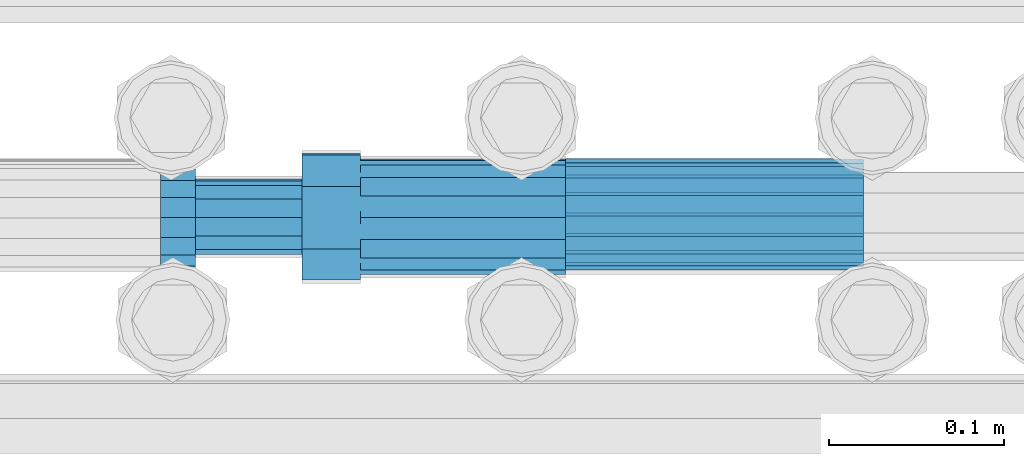
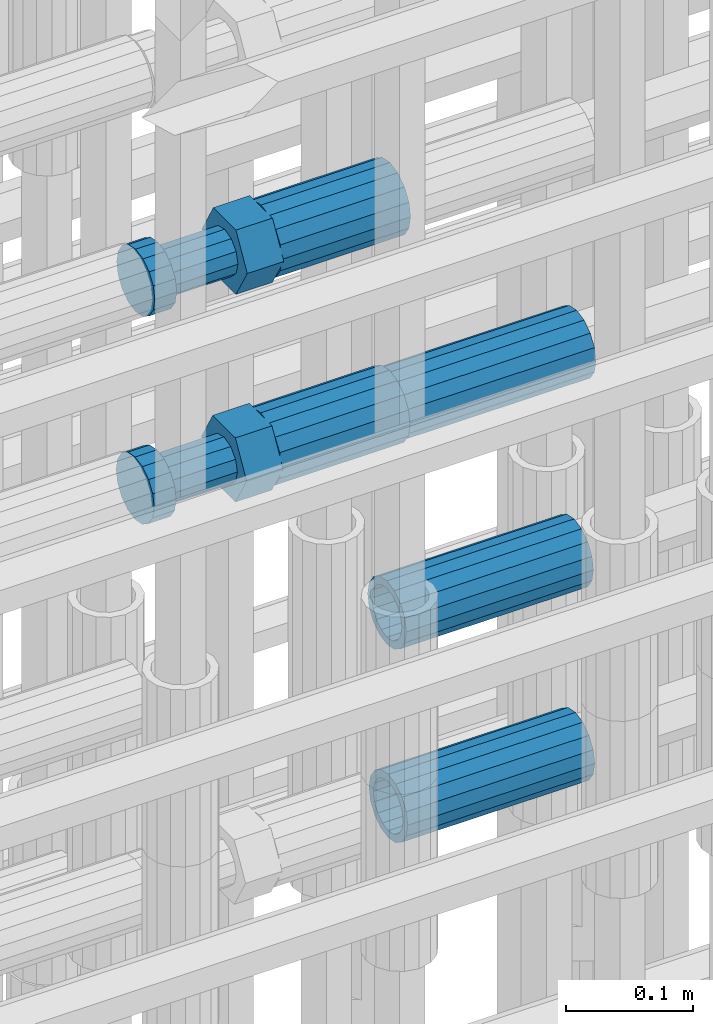
# One storey, part 27 of 119: 5 beams.
"""IFC2X3 building model written with IfcOpenShell, lengths in millimetres."""

from ifc_helpers import new_model, si_unit, frame, origin_with_axes, place, context, subcontext, project, spatial, faceted_brep, material, type_object, element, save


model = new_model("IFC2X3")

# Units and contexts
model_context = context("Model", 3, precision=1e-05, world=origin_with_axes())
body_context = subcontext(model_context, "Body", "Model", "MODEL_VIEW")
ifc_project = project(units=[si_unit("LENGTHUNIT", "METRE", prefix="MILLI"), si_unit("AREAUNIT", "SQUARE_METRE"), si_unit("VOLUMEUNIT", "CUBIC_METRE"), si_unit("MASSUNIT", "GRAM", prefix="KILO"), si_unit("TIMEUNIT", "SECOND"), si_unit("PLANEANGLEUNIT", "RADIAN"), si_unit("SOLIDANGLEUNIT", "STERADIAN"), si_unit("THERMODYNAMICTEMPERATUREUNIT", "DEGREE_CELSIUS"), si_unit("LUMINOUSINTENSITYUNIT", "LUMEN")], contexts=[model_context])

# Site, building, storey
site_placement = place(None, origin_with_axes())
site = spatial("IfcSite", under=ifc_project, at=site_placement, CompositionType="ELEMENT")
building_placement = place(site_placement, origin_with_axes())
building = spatial("IfcBuilding", under=site, at=building_placement, Name="Undefined", CompositionType="ELEMENT")
storey_placement = place(building_placement, origin_with_axes())
storey = spatial("IfcBuildingStorey", under=building, at=storey_placement, Name="Undefined", CompositionType="ELEMENT", Elevation=0.0)

# Beams
ifc_material = material(Name="STEEL/S275")
beam_type_1 = type_object("IfcBeamType", PredefinedType="NOTDEFINED")
beam_1_placement = place(storey_placement, frame((2035520.01345925, 6205213.05560864, 20146.6568409387), z_axis=(0.0, 0.0, 1.0), x_axis=(-0.999999999998145, -1.92600247614167e-06, 0.0)))
element("IfcBeam", 1, at=beam_1_placement, inside=storey, type_object=beam_type_1, material=ifc_material, Name="AG40N", context=body_context, shape_type="Brep", body=[
    faceted_brep([(1.62981450557709e-09, -23.4999999990687, 0.0), (7.45058059692383e-09, -21.7111690142192, 8.99306066057534), (170.000002125278, -21.711168999318, 8.99306066022245), (170.000002127141, -23.4999999844003, -3.66071617463604e-10), (4.65661287307739e-09, -16.6170093587134, 16.6170093578889), (170.000002122484, -16.6170093440451, 16.6170093575288), (1.86264514923096e-09, -8.99306066217832, 21.7111690140277), (170.000002118759, -8.99306064750999, 21.7111690136603), (2.3283064365387e-10, 9.31322574615479e-10, 23.5), (170.000002114102, 1.28056854009628e-08, 23.4999999996485), (-6.51925802230835e-09, 8.99306065868586, 21.7111690140241), (170.00000211224, 8.99306067335419, 21.7111690136639), (-7.45058059692383e-09, 16.6170093561523, 16.6170093578853), (170.000002109446, 16.6170093708206, 16.6170093575324), (-9.31322574615479e-09, 21.711169013055, 8.99306066057534), (170.000002108514, 21.7111690277234, 8.99306066022245), (-1.16415321826935e-09, 23.5000000009313, 0.0), (170.000002108514, 23.5000000144355, -3.66071617463604e-10), (-8.38190317153931e-09, 21.7111690151505, -8.99306066059444), (170.000002110377, 21.7111690300517, -8.9930606609546), (-5.58793544769287e-09, 16.6170093598776, -16.6170093579008), (170.000002113171, 16.6170093745459, -16.6170093582609), (-9.31322574615479e-10, 8.99306066334248, -21.7111690140396), (170.000002115965, 8.99306067801081, -21.7111690143961), (2.3283064365387e-10, 9.31322574615479e-10, -23.5), (170.00000211969, 1.7927959561348e-08, -23.5000000003843), (5.58793544769287e-09, -8.99306065752171, -21.7111690140396), (170.000002123415, -8.99306064285338, -21.7111690143961), (8.38190317153931e-09, -16.6170093549881, -16.6170093579008), (170.000002125278, -16.6170093403198, -16.6170093582646), (9.31322574615479e-09, -21.7111690121237, -8.99306066059444), (170.000002127141, -21.7111689972226, -8.9930606609546), (1.11758708953857e-08, -30.4999999990687, -9.54969436861575e-12), (1.30385160446167e-08, -28.1783257392235, -11.6718446871514), (170.000002129003, -28.1783257243223, -11.6718446875116), (170.000002129935, -30.4999999841675, -3.66071617463604e-10), (1.02445483207703e-08, -21.5667568228673, -21.5667568262129), (170.000002128072, -21.566756808199, -21.5667568265694), (7.45058059692383e-09, -11.6718446831219, -28.1783257416196), (170.000002125278, -11.6718446684536, -28.1783257419834), (3.72529029846191e-09, 3.95812094211578e-09, -30.5000000000277), (170.00000211969, 1.83936208486557e-08, -30.5000000003879), (-9.31322574615479e-10, 11.6718446905725, -28.1783257416232), (170.000002115965, 11.6718447052408, -28.1783257419797), (-6.51925802230835e-09, 21.5667568286881, -21.5667568262093), (170.000002110377, 21.5667568433564, -21.5667568265694), (-9.31322574615479e-09, 28.178325742716, -11.6718446871478), (170.000002108514, 28.1783257573843, -11.6718446875079), (-1.21071934700012e-08, 30.5, -5.91171556152403e-12), (170.000002106652, 30.5000000144355, -3.62433638656512e-10), (-1.21071934700012e-08, 28.1783257401548, 11.6718446871359), (170.00000210572, 28.1783257548232, 11.6718446867794), (-1.02445483207703e-08, 21.5667568240315, 21.5667568261974), (170.000002107583, 21.566756838467, 21.5667568258409), (-7.45058059692383e-09, 11.671844684286, 28.1783257416041), (170.000002110377, 11.6718446989544, 28.178325741244), (-2.79396772384644e-09, -2.56113708019257e-09, 30.5000000000159), (170.000002114102, 1.18743628263474e-08, 30.4999999996558), (1.86264514923096e-09, -11.6718446896411, 28.1783257416114), (170.000002118759, -11.67184467474, 28.178325741244), (7.45058059692383e-09, -21.5667568275239, 21.5667568261974), (170.000002123415, -21.5667568126228, 21.5667568258373), (1.02445483207703e-08, -28.1783257415518, 11.6718446871359), (170.000002127141, -28.1783257271163, 11.6718446867794)], [[[0, 1, 2, 3]], [[1, 4, 5, 2]], [[4, 6, 7, 5]], [[6, 8, 9, 7]], [[8, 10, 11, 9]], [[10, 12, 13, 11]], [[12, 14, 15, 13]], [[14, 16, 17, 15]], [[16, 18, 19, 17]], [[18, 20, 21, 19]], [[20, 22, 23, 21]], [[22, 24, 25, 23]], [[24, 26, 27, 25]], [[26, 28, 29, 27]], [[28, 30, 31, 29]], [[30, 0, 3, 31]], [[32, 33, 34, 35]], [[33, 36, 37, 34]], [[36, 38, 39, 37]], [[38, 40, 41, 39]], [[40, 42, 43, 41]], [[42, 44, 45, 43]], [[44, 46, 47, 45]], [[46, 48, 49, 47]], [[48, 50, 51, 49]], [[50, 52, 53, 51]], [[52, 54, 55, 53]], [[54, 56, 57, 55]], [[56, 58, 59, 57]], [[58, 60, 61, 59]], [[60, 62, 63, 61]], [[62, 32, 35, 63]], [[37, 39, 41, 43, 45, 47, 49, 51, 53, 55, 57, 59, 61, 63, 35, 34], [5, 7, 9, 11, 13, 15, 17, 19, 21, 23, 25, 27, 29, 31, 3, 2]], [[62, 60, 58, 56, 54, 52, 50, 48, 46, 44, 42, 40, 38, 36, 33, 32], [30, 28, 26, 24, 22, 20, 18, 16, 14, 12, 10, 8, 6, 4, 1, 0]]]),
])
beam_2_placement = place(storey_placement, frame((2035519.01345925, 6205215.21560864, 19945.3068409387), z_axis=(0.0, 0.0, 1.0), x_axis=(-0.999999999998145, -1.92600247614167e-06, 0.0)))
element("IfcBeam", 2, at=beam_2_placement, inside=storey, type_object=beam_type_1, material=ifc_material, Name="AG40N", context=body_context, shape_type="Brep", body=[
    faceted_brep([(1.62981450557709e-09, -23.4999999990687, 0.0), (7.45058059692383e-09, -21.7111690142192, 8.99306066057534), (170.000002125278, -21.711168999318, 8.99306066022245), (170.000002127141, -23.4999999844003, -3.66071617463604e-10), (4.65661287307739e-09, -16.6170093587134, 16.6170093578889), (170.000002122484, -16.6170093440451, 16.6170093575288), (1.86264514923096e-09, -8.99306066217832, 21.7111690140277), (170.000002118759, -8.99306064750999, 21.7111690136603), (2.3283064365387e-10, 9.31322574615479e-10, 23.5), (170.000002114102, 1.28056854009628e-08, 23.4999999996485), (-6.51925802230835e-09, 8.99306065868586, 21.7111690140241), (170.00000211224, 8.99306067335419, 21.7111690136639), (-7.45058059692383e-09, 16.6170093561523, 16.6170093578853), (170.000002109446, 16.6170093708206, 16.6170093575324), (-9.31322574615479e-09, 21.711169013055, 8.99306066057534), (170.000002108514, 21.7111690277234, 8.99306066022245), (-1.16415321826935e-09, 23.5000000009313, 0.0), (170.000002108514, 23.5000000144355, -3.66071617463604e-10), (-8.38190317153931e-09, 21.7111690151505, -8.99306066059444), (170.000002110377, 21.7111690300517, -8.9930606609546), (-5.58793544769287e-09, 16.6170093598776, -16.6170093579008), (170.000002113171, 16.6170093745459, -16.6170093582609), (-9.31322574615479e-10, 8.99306066334248, -21.7111690140396), (170.000002115965, 8.99306067801081, -21.7111690143961), (2.3283064365387e-10, 9.31322574615479e-10, -23.5), (170.00000211969, 1.7927959561348e-08, -23.5000000003843), (5.58793544769287e-09, -8.99306065752171, -21.7111690140396), (170.000002123415, -8.99306064285338, -21.7111690143961), (8.38190317153931e-09, -16.6170093549881, -16.6170093579008), (170.000002125278, -16.6170093403198, -16.6170093582646), (9.31322574615479e-09, -21.7111690121237, -8.99306066059444), (170.000002127141, -21.7111689972226, -8.9930606609546), (1.11758708953857e-08, -30.4999999990687, -9.54969436861575e-12), (1.30385160446167e-08, -28.1783257392235, -11.6718446871514), (170.000002129003, -28.1783257243223, -11.6718446875116), (170.000002129935, -30.4999999841675, -3.66071617463604e-10), (1.02445483207703e-08, -21.5667568228673, -21.5667568262129), (170.000002128072, -21.566756808199, -21.5667568265694), (7.45058059692383e-09, -11.6718446831219, -28.1783257416196), (170.000002125278, -11.6718446684536, -28.1783257419834), (3.72529029846191e-09, 3.95812094211578e-09, -30.5000000000277), (170.00000211969, 1.83936208486557e-08, -30.5000000003879), (-9.31322574615479e-10, 11.6718446905725, -28.1783257416232), (170.000002115965, 11.6718447052408, -28.1783257419797), (-6.51925802230835e-09, 21.5667568286881, -21.5667568262093), (170.000002110377, 21.5667568433564, -21.5667568265694), (-9.31322574615479e-09, 28.178325742716, -11.6718446871478), (170.000002108514, 28.1783257573843, -11.6718446875079), (-1.21071934700012e-08, 30.5, -5.91171556152403e-12), (170.000002106652, 30.5000000144355, -3.62433638656512e-10), (-1.21071934700012e-08, 28.1783257401548, 11.6718446871359), (170.00000210572, 28.1783257548232, 11.6718446867794), (-1.02445483207703e-08, 21.5667568240315, 21.5667568261974), (170.000002107583, 21.566756838467, 21.5667568258409), (-7.45058059692383e-09, 11.671844684286, 28.1783257416041), (170.000002110377, 11.6718446989544, 28.178325741244), (-2.79396772384644e-09, -2.56113708019257e-09, 30.5000000000159), (170.000002114102, 1.18743628263474e-08, 30.4999999996558), (1.86264514923096e-09, -11.6718446896411, 28.1783257416114), (170.000002118759, -11.67184467474, 28.178325741244), (7.45058059692383e-09, -21.5667568275239, 21.5667568261974), (170.000002123415, -21.5667568126228, 21.5667568258373), (1.02445483207703e-08, -28.1783257415518, 11.6718446871359), (170.000002127141, -28.1783257271163, 11.6718446867794)], [[[0, 1, 2, 3]], [[1, 4, 5, 2]], [[4, 6, 7, 5]], [[6, 8, 9, 7]], [[8, 10, 11, 9]], [[10, 12, 13, 11]], [[12, 14, 15, 13]], [[14, 16, 17, 15]], [[16, 18, 19, 17]], [[18, 20, 21, 19]], [[20, 22, 23, 21]], [[22, 24, 25, 23]], [[24, 26, 27, 25]], [[26, 28, 29, 27]], [[28, 30, 31, 29]], [[30, 0, 3, 31]], [[32, 33, 34, 35]], [[33, 36, 37, 34]], [[36, 38, 39, 37]], [[38, 40, 41, 39]], [[40, 42, 43, 41]], [[42, 44, 45, 43]], [[44, 46, 47, 45]], [[46, 48, 49, 47]], [[48, 50, 51, 49]], [[50, 52, 53, 51]], [[52, 54, 55, 53]], [[54, 56, 57, 55]], [[56, 58, 59, 57]], [[58, 60, 61, 59]], [[60, 62, 63, 61]], [[62, 32, 35, 63]], [[37, 39, 41, 43, 45, 47, 49, 51, 53, 55, 57, 59, 61, 63, 35, 34], [5, 7, 9, 11, 13, 15, 17, 19, 21, 23, 25, 27, 29, 31, 3, 2]], [[62, 60, 58, 56, 54, 52, 50, 48, 46, 44, 42, 40, 38, 36, 33, 32], [30, 28, 26, 24, 22, 20, 18, 16, 14, 12, 10, 8, 6, 4, 1, 0]]]),
])
beam_3_placement = place(storey_placement, frame((2035519.99345925, 6205214.81562195, 19759.4968409387), z_axis=(0.0, 0.0, 1.0), x_axis=(-0.999999999998145, -1.92600247614167e-06, 0.0)))
element("IfcBeam", 3, at=beam_3_placement, inside=storey, type_object=beam_type_1, material=ifc_material, Name="AG40N", context=body_context, shape_type="Brep", body=[
    faceted_brep([(1.62981450557709e-09, -23.4999999990687, 0.0), (7.45058059692383e-09, -21.7111690142192, 8.99306066057534), (170.000002125278, -21.711168999318, 8.99306066022245), (170.000002127141, -23.4999999844003, -3.66071617463604e-10), (4.65661287307739e-09, -16.6170093587134, 16.6170093578889), (170.000002122484, -16.6170093440451, 16.6170093575288), (1.86264514923096e-09, -8.99306066217832, 21.7111690140277), (170.000002118759, -8.99306064750999, 21.7111690136603), (2.3283064365387e-10, 9.31322574615479e-10, 23.5), (170.000002114102, 1.28056854009628e-08, 23.4999999996485), (-6.51925802230835e-09, 8.99306065868586, 21.7111690140241), (170.00000211224, 8.99306067335419, 21.7111690136639), (-7.45058059692383e-09, 16.6170093561523, 16.6170093578853), (170.000002109446, 16.6170093708206, 16.6170093575324), (-9.31322574615479e-09, 21.711169013055, 8.99306066057534), (170.000002108514, 21.7111690277234, 8.99306066022245), (-1.16415321826935e-09, 23.5000000009313, 0.0), (170.000002108514, 23.5000000144355, -3.66071617463604e-10), (-8.38190317153931e-09, 21.7111690151505, -8.99306066059444), (170.000002110377, 21.7111690300517, -8.9930606609546), (-5.58793544769287e-09, 16.6170093598776, -16.6170093579008), (170.000002113171, 16.6170093745459, -16.6170093582609), (-9.31322574615479e-10, 8.99306066334248, -21.7111690140396), (170.000002115965, 8.99306067801081, -21.7111690143961), (2.3283064365387e-10, 9.31322574615479e-10, -23.5), (170.00000211969, 1.7927959561348e-08, -23.5000000003843), (5.58793544769287e-09, -8.99306065752171, -21.7111690140396), (170.000002123415, -8.99306064285338, -21.7111690143961), (8.38190317153931e-09, -16.6170093549881, -16.6170093579008), (170.000002125278, -16.6170093403198, -16.6170093582646), (9.31322574615479e-09, -21.7111690121237, -8.99306066059444), (170.000002127141, -21.7111689972226, -8.9930606609546), (1.11758708953857e-08, -30.4999999990687, -9.54969436861575e-12), (1.30385160446167e-08, -28.1783257392235, -11.6718446871514), (170.000002129003, -28.1783257243223, -11.6718446875116), (170.000002129935, -30.4999999841675, -3.66071617463604e-10), (1.02445483207703e-08, -21.5667568228673, -21.5667568262129), (170.000002128072, -21.566756808199, -21.5667568265694), (7.45058059692383e-09, -11.6718446831219, -28.1783257416196), (170.000002125278, -11.6718446684536, -28.1783257419834), (3.72529029846191e-09, 3.95812094211578e-09, -30.5000000000277), (170.00000211969, 1.83936208486557e-08, -30.5000000003879), (-9.31322574615479e-10, 11.6718446905725, -28.1783257416232), (170.000002115965, 11.6718447052408, -28.1783257419797), (-6.51925802230835e-09, 21.5667568286881, -21.5667568262093), (170.000002110377, 21.5667568433564, -21.5667568265694), (-9.31322574615479e-09, 28.178325742716, -11.6718446871478), (170.000002108514, 28.1783257573843, -11.6718446875079), (-1.21071934700012e-08, 30.5, -5.91171556152403e-12), (170.000002106652, 30.5000000144355, -3.62433638656512e-10), (-1.21071934700012e-08, 28.1783257401548, 11.6718446871359), (170.00000210572, 28.1783257548232, 11.6718446867794), (-1.02445483207703e-08, 21.5667568240315, 21.5667568261974), (170.000002107583, 21.566756838467, 21.5667568258409), (-7.45058059692383e-09, 11.671844684286, 28.1783257416041), (170.000002110377, 11.6718446989544, 28.178325741244), (-2.79396772384644e-09, -2.56113708019257e-09, 30.5000000000159), (170.000002114102, 1.18743628263474e-08, 30.4999999996558), (1.86264514923096e-09, -11.6718446896411, 28.1783257416114), (170.000002118759, -11.67184467474, 28.178325741244), (7.45058059692383e-09, -21.5667568275239, 21.5667568261974), (170.000002123415, -21.5667568126228, 21.5667568258373), (1.02445483207703e-08, -28.1783257415518, 11.6718446871359), (170.000002127141, -28.1783257271163, 11.6718446867794)], [[[0, 1, 2, 3]], [[1, 4, 5, 2]], [[4, 6, 7, 5]], [[6, 8, 9, 7]], [[8, 10, 11, 9]], [[10, 12, 13, 11]], [[12, 14, 15, 13]], [[14, 16, 17, 15]], [[16, 18, 19, 17]], [[18, 20, 21, 19]], [[20, 22, 23, 21]], [[22, 24, 25, 23]], [[24, 26, 27, 25]], [[26, 28, 29, 27]], [[28, 30, 31, 29]], [[30, 0, 3, 31]], [[32, 33, 34, 35]], [[33, 36, 37, 34]], [[36, 38, 39, 37]], [[38, 40, 41, 39]], [[40, 42, 43, 41]], [[42, 44, 45, 43]], [[44, 46, 47, 45]], [[46, 48, 49, 47]], [[48, 50, 51, 49]], [[50, 52, 53, 51]], [[52, 54, 55, 53]], [[54, 56, 57, 55]], [[56, 58, 59, 57]], [[58, 60, 61, 59]], [[60, 62, 63, 61]], [[62, 32, 35, 63]], [[37, 39, 41, 43, 45, 47, 49, 51, 53, 55, 57, 59, 61, 63, 35, 34], [5, 7, 9, 11, 13, 15, 17, 19, 21, 23, 25, 27, 29, 31, 3, 2]], [[62, 60, 58, 56, 54, 52, 50, 48, 46, 44, 42, 40, 38, 36, 33, 32], [30, 28, 26, 24, 22, 20, 18, 16, 14, 12, 10, 8, 6, 4, 1, 0]]]),
])
beam_type_2 = type_object("IfcBeamType", Name="ROD65", PredefinedType="NOTDEFINED")
beam_4_placement = place(storey_placement, frame((2035350.01345925, 6205212.13544664, 20346.6568409387), z_axis=(0.0, 0.0, 1.0), x_axis=(-0.999999999998145, -1.92600247614167e-06, 0.0)))
element("IfcBeam", 4, at=beam_4_placement, inside=storey, type_object=beam_type_2, material=ifc_material, Name="AGB40", ObjectType="ROD65", context=body_context, shape_type="Brep", body=[
    faceted_brep([(116.999999999069, 17.8249999252148, 30.8738056446964), (116.999999998137, 22.0056957420893, 23.632628078838), (116.999999999069, 12.4372115600854, 30.0260848066173), (116.999999999069, 8.17543111252598, 30.8738056446964), (117.000000000931, -17.8250000746921, 30.8738056446964), (150.200000001118, -17.8250000723638, 30.8738056446964), (150.199999999255, 17.8249999275431, 30.8738056446964), (117.000000000931, -8.17543109622784, 30.8738056446964), (117.000000001863, -22.0056959956419, 23.6326278985034), (117.000000000931, -12.4372115437873, 30.0260848066173), (117.000000001863, -35.6500000746455, -2.18278728425503e-10), (150.200000002049, -35.6500000723172, -2.18278728425503e-10), (117.000000001863, -30.8443149488885, 8.32369080289209), (117.000000001863, -30.8443149488885, -8.32369080355784), (117.000000002794, -32.4999999918509, 0.0), (117.000000000931, -17.8250000746921, -30.873805645133), (150.200000001118, -17.8250000723638, -30.873805645133), (117.000000001863, -22.0056959961075, -23.6326278982269), (117.000000000931, -8.17543109389953, -30.873805645133), (117.000000000931, -12.4372115437873, -30.0260848066173), (116.999999999069, 17.8249999252148, -30.873805645133), (150.199999999255, 17.8249999275431, -30.873805645133), (116.999999999069, 8.17543111019768, -30.873805645133), (116.999999999069, 12.4372115600854, -30.0260848066173), (116.999999998137, 22.005695742555, -23.6326280785652), (116.999999998137, 35.6499999251682, -2.18278728425503e-10), (150.199999998324, 35.6499999277294, -2.18278728425503e-10), (116.999999998137, 30.8443150522653, -8.32369036550881), (116.999999997206, 32.5000000081491, 0.0), (116.999999998137, 30.8443150522653, 8.32369036483942), (1.86264514923096e-09, -22.9809703885112, 22.9809703885621), (1.86264514923096e-09, -30.0260848065373, 12.4372115518672), (117.000000001863, -30.0260847983882, 12.4372115518672), (117.000000001863, -22.9809703803621, 22.9809703885621), (-1.86264514923096e-09, 22.9809703885112, -22.9809703885621), (-1.86264514923096e-09, 30.0260848065373, -12.4372115518672), (116.999999998137, 30.0260848146863, -12.4372115518672), (116.999999998137, 22.9809703966603, -22.9809703885621), (1.86264514923096e-09, -30.0260848065373, -12.4372115518672), (1.86264514923096e-09, -22.9809703885112, -22.9809703885621), (117.000000001863, -22.9809703803621, -22.9809703885621), (117.000000001863, -30.0260847983882, -12.4372115518672), (9.31322574615479e-10, -12.4372115519363, 30.0260848066173), (0.0, 0.0, 32.5), (-9.31322574615479e-10, 12.4372115519363, 30.0260848066173), (-1.86264514923096e-09, 22.9809703885112, 22.9809703885621), (-1.86264514923096e-09, 30.0260848065373, 12.4372115518672), (-2.79396772384644e-09, 32.5, 0.0), (-9.31322574615479e-10, 12.4372115519363, -30.0260848066173), (0.0, 0.0, -32.5), (9.31322574615479e-10, -12.4372115519363, -30.0260848066173), (2.79396772384644e-09, -32.5, 0.0), (116.999999998137, 22.9809703966603, 22.9809703885621), (116.999999998137, 30.0260848146863, 12.4372115518672), (117.0, 8.14907252788544e-09, -32.5), (117.0, 8.14907252788544e-09, 32.5), (150.200000000186, -10.5000000959262, 18.1865334791873), (150.199999999255, -9.59262251853943e-08, 20.9999999997126), (150.199999998324, 10.4999999040738, 18.1865334791873), (150.199999997392, 18.1865333835594, 10.4999999997126), (150.199999997392, 20.9999999040738, -2.87400325760245e-10), (150.199999997392, 18.1865333835594, -10.5000000002874), (150.199999998324, 10.4999999040738, -18.1865334797621), (150.199999999255, -9.59262251853943e-08, -21.0000000002874), (150.200000000186, -10.5000000959262, -18.1865334797621), (150.200000000186, -18.1865335754119, -10.5000000002874), (150.200000001118, -21.0000000959262, -2.87400325760245e-10), (150.200000000186, -18.1865335754119, 10.4999999997126), (210.979999999516, 10.4999999082647, 18.1865334791873), (210.979999999516, -9.17352735996246e-08, 20.9999999997126), (210.979999997653, 18.1865333877504, 10.4999999997126), (210.979999997653, 20.9999999082647, -2.87400325760245e-10), (210.979999997653, 18.1865333877504, -10.5000000002874), (210.979999999516, 10.4999999082647, -18.1865334797621), (210.979999999516, -9.17352735996246e-08, -21.0000000002874), (210.979999999516, -10.5000000917353, -18.1865334797621), (210.980000000447, -18.1865335712209, -10.5000000002874), (210.980000001378, -21.0000000917353, -2.87400325760245e-10), (210.980000000447, -18.1865335712209, 10.4999999997126), (210.979999999516, -10.5000000917353, 18.1865334791873), (211.001368402503, -27.7269939335529, -11.4911163272045), (211.003082515672, -21.2238095656503, -21.2238154190527), (231.002518340945, -21.2131946226582, -21.2132004554769), (231.000804228708, -27.7163789905608, -11.4805013636287), (211.001368415542, -11.4911086384673, -27.7269970399575), (231.000804241747, -11.4804936954752, -27.7163820763781), (210.996487061493, -0.0106066407170147, -30.0106107396168), (230.995922887698, 8.30227509140968e-06, -29.999995776041), (210.98918159306, 11.4698940692469, -27.7269970332745), (230.988617419265, 11.4805090120062, -27.7163820696951), (210.980564201251, 21.2025913291145, -21.2238154067054), (230.980000027455, 21.2132062721066, -21.2132004431296), (210.971946807578, 27.7057702087332, -11.4911163110701), (230.971382633783, 27.7163851517253, -11.4805013474943), (210.964641331695, 29.9893806746695, -0.0106149565435771), (230.9640771579, 29.9999956176616, 7.03221303410828e-09), (210.959759964608, 27.7057637346443, 11.4698863966551), (230.959195790812, 27.7163786776364, 11.4805013602345), (210.958045851439, 21.2025793667417, 21.2025854885032), (230.957481677644, 21.2131943097338, 21.2132004520827), (210.959759951569, 11.4698784395587, 27.705767109408), (230.959195776843, 11.4804933823179, 27.7163820729838), (210.964641305618, -0.0106235581915826, 29.9893808090674), (230.964077131823, -8.61519947648048e-06, 29.9999957726432), (210.971946774051, -11.4911242681555, 27.7057671027251), (230.971382599324, -11.4805093251634, 27.7163820663009), (210.98056416586, -21.2238215280231, 21.2025854761559), (230.979999991134, -21.2132065852638, 21.2132004397354), (210.989181559533, -27.7270004076418, 11.4698863805206), (230.988617384806, -27.7163854646496, 11.4805013441), (210.996487035416, -30.0106108735781, -0.0106149740058754), (230.995922861621, -29.999995930586, -1.04300852399319e-08)], [[[0, 1, 2, 3]], [[4, 5, 6, 0, 3, 7]], [[8, 4, 7, 9]], [[10, 11, 5, 4, 8, 12]], [[13, 10, 12, 14]], [[15, 16, 11, 10, 13, 17]], [[18, 15, 17, 19]], [[20, 21, 16, 15, 18, 22]], [[20, 22, 23, 24]], [[25, 26, 21, 20, 24, 27]], [[25, 27, 28, 29]], [[30, 31, 32, 33]], [[34, 35, 36, 37]], [[38, 39, 40, 41]], [[31, 30, 42, 43, 44, 45, 46, 47, 35, 34, 48, 49, 50, 39, 38, 51]], [[46, 45, 52, 53]], [[28, 47, 46, 53, 29]], [[27, 36, 35, 47, 28]], [[24, 37, 36, 27]], [[23, 48, 34, 37, 24]], [[22, 54, 49, 48, 23]], [[18, 54, 22]], [[19, 50, 49, 54, 18]], [[17, 40, 39, 50, 19]], [[13, 41, 40, 17]], [[14, 51, 38, 41, 13]], [[12, 32, 31, 51, 14]], [[8, 33, 32, 12]], [[9, 42, 30, 33, 8]], [[7, 55, 43, 42, 9]], [[3, 55, 7]], [[2, 44, 43, 55, 3]], [[1, 52, 45, 44, 2]], [[29, 53, 52, 1]], [[0, 6, 26, 25, 29, 1]], [[5, 11, 16, 21, 26, 6], [56, 57, 58, 59, 60, 61, 62, 63, 64, 65, 66, 67]], [[68, 58, 57, 69]], [[70, 59, 58, 68]], [[71, 60, 59, 70]], [[72, 61, 60, 71]], [[73, 62, 61, 72]], [[74, 63, 62, 73]], [[75, 64, 63, 74]], [[76, 65, 64, 75]], [[77, 66, 65, 76]], [[78, 67, 66, 77]], [[79, 56, 67, 78]], [[69, 57, 56, 79]], [[80, 81, 82, 83]], [[81, 84, 85, 82]], [[84, 86, 87, 85]], [[86, 88, 89, 87]], [[88, 90, 91, 89]], [[90, 92, 93, 91]], [[92, 94, 95, 93]], [[94, 96, 97, 95]], [[96, 98, 99, 97]], [[98, 100, 101, 99]], [[100, 102, 103, 101]], [[102, 104, 105, 103]], [[104, 106, 107, 105]], [[106, 108, 109, 107]], [[108, 110, 111, 109]], [[82, 85, 87, 89, 91, 93, 95, 97, 99, 101, 103, 105, 107, 109, 111, 83]], [[110, 80, 83, 111]], [[108, 106, 104, 102, 100, 98, 96, 94, 92, 90, 88, 86, 84, 81, 80, 110], [78, 77, 76, 75, 74, 73, 72, 71, 70, 68, 69, 79]]]),
])
beam_5_placement = place(storey_placement, frame((2035350.01345925, 6205213.05544664, 20146.6568409387), z_axis=(0.0, 0.0, 1.0), x_axis=(-0.999999999998145, -1.92600247614167e-06, 0.0)))
element("IfcBeam", 5, at=beam_5_placement, inside=storey, type_object=beam_type_2, material=ifc_material, Name="AGB40", ObjectType="ROD65", context=body_context, shape_type="Brep", body=[
    faceted_brep([(116.999999999069, 17.8249999252148, 30.8738056446964), (116.999999998137, 22.0056957420893, 23.632628078838), (116.999999999069, 12.4372115600854, 30.0260848066173), (116.999999999069, 8.17543111252598, 30.8738056446964), (117.000000000931, -17.8250000746921, 30.8738056446964), (150.200000001118, -17.8250000723638, 30.8738056446964), (150.199999999255, 17.8249999275431, 30.8738056446964), (117.000000000931, -8.17543109622784, 30.8738056446964), (117.000000001863, -22.0056959956419, 23.6326278985034), (117.000000000931, -12.4372115437873, 30.0260848066173), (117.000000001863, -35.6500000746455, -2.18278728425503e-10), (150.200000002049, -35.6500000723172, -2.18278728425503e-10), (117.000000001863, -30.8443149488885, 8.32369080289209), (117.000000001863, -30.8443149488885, -8.32369080355784), (117.000000002794, -32.4999999918509, 0.0), (117.000000000931, -17.8250000746921, -30.873805645133), (150.200000001118, -17.8250000723638, -30.873805645133), (117.000000001863, -22.0056959961075, -23.6326278982269), (117.000000000931, -8.17543109389953, -30.873805645133), (117.000000000931, -12.4372115437873, -30.0260848066173), (116.999999999069, 17.8249999252148, -30.873805645133), (150.199999999255, 17.8249999275431, -30.873805645133), (116.999999999069, 8.17543111019768, -30.873805645133), (116.999999999069, 12.4372115600854, -30.0260848066173), (116.999999998137, 22.005695742555, -23.6326280785652), (116.999999998137, 35.6499999251682, -2.18278728425503e-10), (150.199999998324, 35.6499999277294, -2.18278728425503e-10), (116.999999998137, 30.8443150522653, -8.32369036550881), (116.999999997206, 32.5000000081491, 0.0), (116.999999998137, 30.8443150522653, 8.32369036483942), (1.86264514923096e-09, -22.9809703885112, 22.9809703885621), (1.86264514923096e-09, -30.0260848065373, 12.4372115518672), (117.000000001863, -30.0260847983882, 12.4372115518672), (117.000000001863, -22.9809703803621, 22.9809703885621), (-1.86264514923096e-09, 22.9809703885112, -22.9809703885621), (-1.86264514923096e-09, 30.0260848065373, -12.4372115518672), (116.999999998137, 30.0260848146863, -12.4372115518672), (116.999999998137, 22.9809703966603, -22.9809703885621), (1.86264514923096e-09, -30.0260848065373, -12.4372115518672), (1.86264514923096e-09, -22.9809703885112, -22.9809703885621), (117.000000001863, -22.9809703803621, -22.9809703885621), (117.000000001863, -30.0260847983882, -12.4372115518672), (9.31322574615479e-10, -12.4372115519363, 30.0260848066173), (0.0, 0.0, 32.5), (-9.31322574615479e-10, 12.4372115519363, 30.0260848066173), (-1.86264514923096e-09, 22.9809703885112, 22.9809703885621), (-1.86264514923096e-09, 30.0260848065373, 12.4372115518672), (-2.79396772384644e-09, 32.5, 0.0), (-9.31322574615479e-10, 12.4372115519363, -30.0260848066173), (0.0, 0.0, -32.5), (9.31322574615479e-10, -12.4372115519363, -30.0260848066173), (2.79396772384644e-09, -32.5, 0.0), (116.999999998137, 22.9809703966603, 22.9809703885621), (116.999999998137, 30.0260848146863, 12.4372115518672), (117.0, 8.14907252788544e-09, -32.5), (117.0, 8.14907252788544e-09, 32.5), (150.200000000186, -10.5000000959262, 18.1865334791873), (150.199999999255, -9.59262251853943e-08, 20.9999999997126), (150.199999998324, 10.4999999040738, 18.1865334791873), (150.199999997392, 18.1865333835594, 10.4999999997126), (150.199999997392, 20.9999999040738, -2.87400325760245e-10), (150.199999997392, 18.1865333835594, -10.5000000002874), (150.199999998324, 10.4999999040738, -18.1865334797621), (150.199999999255, -9.59262251853943e-08, -21.0000000002874), (150.200000000186, -10.5000000959262, -18.1865334797621), (150.200000000186, -18.1865335754119, -10.5000000002874), (150.200000001118, -21.0000000959262, -2.87400325760245e-10), (150.200000000186, -18.1865335754119, 10.4999999997126), (210.979999999516, 10.4999999082647, 18.1865334791873), (210.979999999516, -9.17352735996246e-08, 20.9999999997126), (210.979999997653, 18.1865333877504, 10.4999999997126), (210.979999997653, 20.9999999082647, -2.87400325760245e-10), (210.979999997653, 18.1865333877504, -10.5000000002874), (210.979999999516, 10.4999999082647, -18.1865334797621), (210.979999999516, -9.17352735996246e-08, -21.0000000002874), (210.979999999516, -10.5000000917353, -18.1865334797621), (210.980000000447, -18.1865335712209, -10.5000000002874), (210.980000001378, -21.0000000917353, -2.87400325760245e-10), (210.980000000447, -18.1865335712209, 10.4999999997126), (210.979999999516, -10.5000000917353, 18.1865334791873), (211.001368402503, -27.7269939335529, -11.4911163272045), (211.003082515672, -21.2238095656503, -21.2238154190527), (231.002518340945, -21.2131946226582, -21.2132004554769), (231.000804228708, -27.7163789905608, -11.4805013636287), (211.001368415542, -11.4911086384673, -27.7269970399575), (231.000804241747, -11.4804936954752, -27.7163820763781), (210.996487061493, -0.0106066407170147, -30.0106107396168), (230.995922887698, 8.30227509140968e-06, -29.999995776041), (210.98918159306, 11.4698940692469, -27.7269970332745), (230.988617419265, 11.4805090120062, -27.7163820696951), (210.980564201251, 21.2025913291145, -21.2238154067054), (230.980000027455, 21.2132062721066, -21.2132004431296), (210.971946807578, 27.7057702087332, -11.4911163110701), (230.971382633783, 27.7163851517253, -11.4805013474943), (210.964641331695, 29.9893806746695, -0.0106149565435771), (230.9640771579, 29.9999956176616, 7.03221303410828e-09), (210.959759964608, 27.7057637346443, 11.4698863966551), (230.959195790812, 27.7163786776364, 11.4805013602345), (210.958045851439, 21.2025793667417, 21.2025854885032), (230.957481677644, 21.2131943097338, 21.2132004520827), (210.959759951569, 11.4698784395587, 27.705767109408), (230.959195776843, 11.4804933823179, 27.7163820729838), (210.964641305618, -0.0106235581915826, 29.9893808090674), (230.964077131823, -8.61519947648048e-06, 29.9999957726432), (210.971946774051, -11.4911242681555, 27.7057671027251), (230.971382599324, -11.4805093251634, 27.7163820663009), (210.98056416586, -21.2238215280231, 21.2025854761559), (230.979999991134, -21.2132065852638, 21.2132004397354), (210.989181559533, -27.7270004076418, 11.4698863805206), (230.988617384806, -27.7163854646496, 11.4805013441), (210.996487035416, -30.0106108735781, -0.0106149740058754), (230.995922861621, -29.999995930586, -1.04300852399319e-08)], [[[0, 1, 2, 3]], [[4, 5, 6, 0, 3, 7]], [[8, 4, 7, 9]], [[10, 11, 5, 4, 8, 12]], [[13, 10, 12, 14]], [[15, 16, 11, 10, 13, 17]], [[18, 15, 17, 19]], [[20, 21, 16, 15, 18, 22]], [[20, 22, 23, 24]], [[25, 26, 21, 20, 24, 27]], [[25, 27, 28, 29]], [[30, 31, 32, 33]], [[34, 35, 36, 37]], [[38, 39, 40, 41]], [[31, 30, 42, 43, 44, 45, 46, 47, 35, 34, 48, 49, 50, 39, 38, 51]], [[46, 45, 52, 53]], [[28, 47, 46, 53, 29]], [[27, 36, 35, 47, 28]], [[24, 37, 36, 27]], [[23, 48, 34, 37, 24]], [[22, 54, 49, 48, 23]], [[18, 54, 22]], [[19, 50, 49, 54, 18]], [[17, 40, 39, 50, 19]], [[13, 41, 40, 17]], [[14, 51, 38, 41, 13]], [[12, 32, 31, 51, 14]], [[8, 33, 32, 12]], [[9, 42, 30, 33, 8]], [[7, 55, 43, 42, 9]], [[3, 55, 7]], [[2, 44, 43, 55, 3]], [[1, 52, 45, 44, 2]], [[29, 53, 52, 1]], [[0, 6, 26, 25, 29, 1]], [[5, 11, 16, 21, 26, 6], [56, 57, 58, 59, 60, 61, 62, 63, 64, 65, 66, 67]], [[68, 58, 57, 69]], [[70, 59, 58, 68]], [[71, 60, 59, 70]], [[72, 61, 60, 71]], [[73, 62, 61, 72]], [[74, 63, 62, 73]], [[75, 64, 63, 74]], [[76, 65, 64, 75]], [[77, 66, 65, 76]], [[78, 67, 66, 77]], [[79, 56, 67, 78]], [[69, 57, 56, 79]], [[80, 81, 82, 83]], [[81, 84, 85, 82]], [[84, 86, 87, 85]], [[86, 88, 89, 87]], [[88, 90, 91, 89]], [[90, 92, 93, 91]], [[92, 94, 95, 93]], [[94, 96, 97, 95]], [[96, 98, 99, 97]], [[98, 100, 101, 99]], [[100, 102, 103, 101]], [[102, 104, 105, 103]], [[104, 106, 107, 105]], [[106, 108, 109, 107]], [[108, 110, 111, 109]], [[82, 85, 87, 89, 91, 93, 95, 97, 99, 101, 103, 105, 107, 109, 111, 83]], [[110, 80, 83, 111]], [[108, 106, 104, 102, 100, 98, 96, 94, 92, 90, 88, 86, 84, 81, 80, 110], [78, 77, 76, 75, 74, 73, 72, 71, 70, 68, 69, 79]]]),
])

save(model, "model.ifc")
